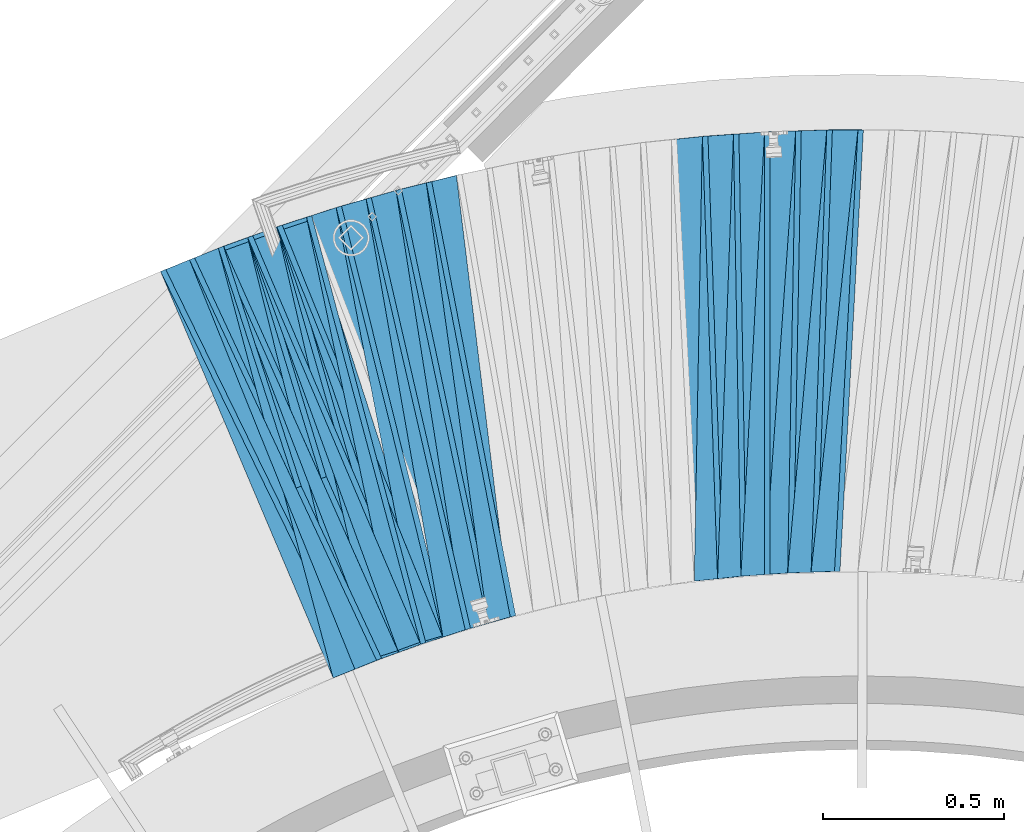
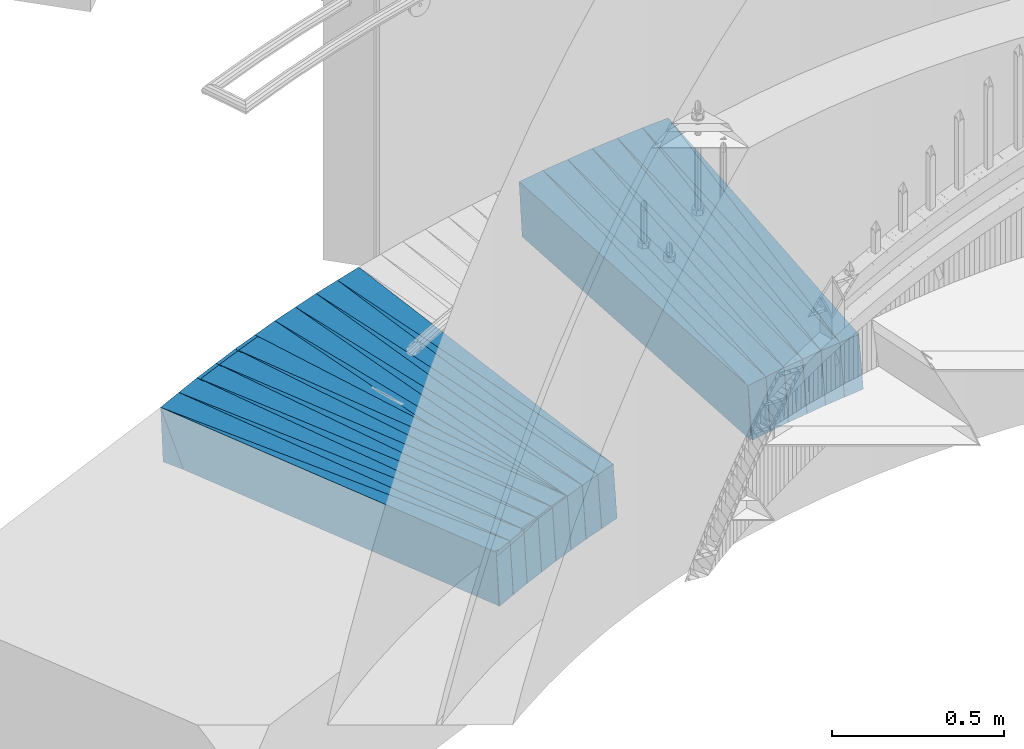
# One storey, part 837 of 975: 38 plates.
"""IFC2X3 building model written with IfcOpenShell, lengths in millimetres."""

from ifc_helpers import new_model, si_unit, frame, origin_with_axes, place, context, subcontext, project, spatial, faceted_brep, material, type_object, element, save


model = new_model("IFC2X3")

# Units and contexts
model_context = context("Model", 3, precision=1e-05, world=origin_with_axes())
body_context = subcontext(model_context, "Body", "Model", "MODEL_VIEW")
ifc_project = project(units=[si_unit("LENGTHUNIT", "METRE", prefix="MILLI"), si_unit("AREAUNIT", "SQUARE_METRE"), si_unit("VOLUMEUNIT", "CUBIC_METRE"), si_unit("MASSUNIT", "GRAM", prefix="KILO"), si_unit("TIMEUNIT", "SECOND"), si_unit("PLANEANGLEUNIT", "RADIAN"), si_unit("SOLIDANGLEUNIT", "STERADIAN"), si_unit("THERMODYNAMICTEMPERATUREUNIT", "DEGREE_CELSIUS"), si_unit("LUMINOUSINTENSITYUNIT", "LUMEN")], contexts=[model_context])

# Site, building, storey
site_placement = place(None, origin_with_axes())
site = spatial("IfcSite", under=ifc_project, at=site_placement, CompositionType="ELEMENT")
building_placement = place(site_placement, origin_with_axes())
building = spatial("IfcBuilding", under=site, at=building_placement, Name="Undefined", CompositionType="ELEMENT")
storey_placement = place(building_placement, origin_with_axes())
storey = spatial("IfcBuildingStorey", under=building, at=storey_placement, Name="Undefined", CompositionType="ELEMENT", Elevation=0.0)

# Plates
ifc_material = material(Name="STEEL/A36")
plate_type_1 = type_object("IfcPlateType", PredefinedType="NOTDEFINED")
plate_1_placement = place(storey_placement, frame((33135.7544163634, 8064.57326011908, -80.0313597914393), z_axis=(0.925334945859308, 0.374702572895314, 0.0579069929903383), x_axis=(0.375109260845974, -0.926971575619367, 0.00409150599831995)))
element("IfcPlate", 1, at=plate_1_placement, inside=storey, type_object=plate_type_1, material=ifc_material, Name="SLAB", context=body_context, shape_type="Brep", body=[
    faceted_brep([(-6.82121026329696e-12, -100.000000000011, -1.09139364212751e-10), (6.13964843744816, -100.000000000007, 85.9115524290755), (6.13964843754457, 100.000000000007, 85.9115524293229), (5.91171556152403e-12, 100.000000000011, 1.09139364212751e-10), (1222.04394531102, -100.000000000158, -3.23780113831162e-09), (1222.04394531112, 99.9999999998563, -2.99041857942939e-09)], [[[0, 1, 2, 3]], [[1, 4, 5, 2]], [[4, 0, 3, 5]], [[5, 3, 2]], [[4, 1, 0]]]),
])
plate_2_placement = place(storey_placement, frame((33054.8117538356, 8035.13147844104, -84.9380845994768), z_axis=(0.918671409330984, 0.390926168424825, 0.05674127702571), x_axis=(0.391343912095998, -0.920235746225737, 0.0040142040009847)))
element("IfcPlate", 2, at=plate_2_placement, inside=storey, type_object=plate_type_1, material=ifc_material, Name="SLAB", context=body_context, shape_type="Brep", body=[
    faceted_brep([(-6.82121026329696e-12, -100.000000000011, -1.09139364212751e-10), (4.49330329882287, -100.000000000016, 86.0390014645745), (4.49330329902114, 100.000000000009, 86.0390014649965), (5.91171556152403e-12, 100.000000000011, 1.09139364212751e-10), (1220.66552734293, -100.000000000056, -2.88127921521664e-09), (1220.66552734313, 99.9999999999702, -2.459273673594e-09)], [[[0, 1, 2, 3]], [[1, 4, 5, 2]], [[4, 0, 3, 5]], [[5, 3, 2]], [[4, 1, 0]]]),
])
plate_3_placement = place(storey_placement, frame((32974.0885574028, 8005.86513753065, -89.9313487506862), z_axis=(0.911678885621115, 0.406802370995397, 0.0579088979792043), x_axis=(0.407266029137052, -0.913300411307338, 0.00409148100137684)))
element("IfcPlate", 3, at=plate_3_placement, inside=storey, type_object=plate_type_1, material=ifc_material, Name="SLAB", context=body_context, shape_type="Brep", body=[
    faceted_brep([(-6.82121026329696e-12, -100.000000000011, -1.09139364212751e-10), (6.07652044296265, -99.9999999999998, 85.9131851196362), (6.07652044284623, 99.9999999999782, 85.9131851192578), (5.91171556152403e-12, 100.000000000011, 1.09139364212751e-10), (1222.05139160054, -100.000000000137, -7.20319803804159e-10), (1222.05139160042, 99.9999999998413, -1.0986695997417e-09)], [[[0, 1, 2, 3]], [[1, 4, 5, 2]], [[4, 0, 3, 5]], [[5, 3, 2]], [[4, 1, 0]]]),
])
plate_4_placement = place(storey_placement, frame((32894.2472778231, 7973.71949863962, -94.8378728433739), z_axis=(0.904478489317947, 0.422723148554099, 0.0567785350078129), x_axis=(0.42319595791562, -0.906029286819346, 0.00401405399919963)))
element("IfcPlate", 4, at=plate_4_placement, inside=storey, type_object=plate_type_1, material=ifc_material, Name="SLAB", context=body_context, shape_type="Brep", body=[
    faceted_brep([(-6.82121026329696e-12, -100.000000000011, -1.09139364212751e-10), (4.57424354575505, -99.9999999999789, 85.9768371585524), (4.57424354547129, 99.9999999999941, 85.9768371580867), (5.91171556152403e-12, 100.000000000011, 1.09139364212751e-10), (1220.71105957185, -99.999999999741, 6.00994098931551e-09), (1220.71105957157, 100.000000000232, 5.54427970200777e-09)], [[[0, 1, 2, 3]], [[1, 4, 5, 2]], [[4, 0, 3, 5]], [[5, 3, 2]], [[4, 1, 0]]]),
])
plate_5_placement = place(storey_placement, frame((32814.5117097274, 7941.65240086744, -99.8316186181916), z_axis=(0.896919890625574, 0.438390985101554, 0.0578623710359128), x_axis=(0.438909982988445, -0.898521723976347, 0.0040912559998923)))
element("IfcPlate", 5, at=plate_5_placement, inside=storey, type_object=plate_type_1, material=ifc_material, Name="SLAB", context=body_context, shape_type="Brep", body=[
    faceted_brep([(-6.82121026329696e-12, -100.000000000011, -1.09139364212751e-10), (6.11307334909816, -99.9999999999957, 85.9797058106051), (6.11307334904541, 100.000000000008, 85.9797058106778), (5.91171556152403e-12, 100.000000000011, 1.09139364212751e-10), (1222.11853027179, -100.000000000163, -1.24418875202537e-09), (1222.11853027174, 99.9999999998415, -1.17870513349771e-09)], [[[0, 1, 2, 3]], [[1, 4, 5, 2]], [[4, 0, 3, 5]], [[5, 3, 2]], [[4, 1, 0]]]),
])
plate_6_placement = place(storey_placement, frame((34654.3102342191, 8330.60518954007, 9.29064641898812), z_axis=(0.99768231764346, -0.0356859870933057, 0.0579353379790892), x_axis=(-0.0355132029959172, -0.999361163885047, -0.0040095549995388)))
element("IfcPlate", 6, at=plate_6_placement, inside=storey, type_object=plate_type_1, material=ifc_material, Name="SLAB", context=body_context, shape_type="Brep", body=[
    faceted_brep([(-6.82121026329696e-12, -100.000000000011, -1.09139364212751e-10), (-3.07418322551348, -100.000000000018, 86.0903549191207), (-3.07418322569538, 99.9999999999866, 86.0903549192008), (5.91171556152403e-12, 100.000000000011, 1.09139364212751e-10), (1222.0806884773, -99.9999999999006, 8.14907252788544e-10), (1222.08068847711, 100.000000000104, 8.94942786544561e-10)], [[[0, 1, 2, 3]], [[1, 4, 5, 2]], [[4, 0, 3, 5]], [[5, 3, 2]], [[4, 1, 0]]]),
])
plate_7_placement = place(storey_placement, frame((34568.2904770862, 8327.71651932735, 4.38403457644043), z_axis=(0.998217432917803, -0.0183894461560285, 0.0567783839948426), x_axis=(-0.0181861060034705, -0.999826229190945, -0.00409597000078224)))
element("IfcPlate", 7, at=plate_7_placement, inside=storey, type_object=plate_type_1, material=ifc_material, Name="SLAB", context=body_context, shape_type="Brep", body=[
    faceted_brep([(-6.82121026329696e-12, -100.000000000011, -1.09139364212751e-10), (-4.58173561107287, -99.9999999999939, 85.9699249268597), (-4.5817356109892, 100.000000000015, 85.9699249270125), (5.91171556152403e-12, 100.000000000011, 1.09139364212751e-10), (1220.71215820214, -100.000000000078, -8.87666828930378e-10), (1220.71215820222, 99.9999999999311, -7.27595761418343e-10)], [[[0, 1, 2, 3]], [[1, 4, 5, 2]], [[4, 0, 3, 5]], [[5, 3, 2]], [[4, 1, 0]]]),
])
plate_8_placement = place(storey_placement, frame((34482.3961116413, 8324.81606906158, -0.609540547740721), z_axis=(0.998322212679924, -0.000808766746195034, 0.0578973709784079), x_axis=(-0.000572827000131128, -0.99999146522926, -0.00409161800093805)))
element("IfcPlate", 8, at=plate_8_placement, inside=storey, type_object=plate_type_1, material=ifc_material, Name="SLAB", context=body_context, shape_type="Brep", body=[
    faceted_brep([(-6.82121026329696e-12, -100.000000000011, -1.09139364212751e-10), (-3.06969547265362, -99.9999999999859, 86.1427688601034), (-3.06969547271365, 100.000000000016, 86.1427688601398), (5.91171556152403e-12, 100.000000000011, 1.09139364212751e-10), (1222.01037597622, -99.9999999997835, 2.84489942714572e-09), (1222.01037597616, 100.000000000219, 2.87400325760245e-09)], [[[0, 1, 2, 3]], [[1, 4, 5, 2]], [[4, 0, 3, 5]], [[5, 3, 2]], [[4, 1, 0]]]),
])
plate_9_placement = place(storey_placement, frame((34396.5889540769, 8318.90883943182, -5.60953580880143), z_axis=(0.998185261867998, 0.0165334455942793, 0.0579036109953177), x_axis=(0.0167938909966302, -0.99985091479929, -0.0040141499991942)))
element("IfcPlate", 9, at=plate_9_placement, inside=storey, type_object=plate_type_1, material=ifc_material, Name="SLAB", context=body_context, shape_type="Brep", body=[
    faceted_brep([(-6.82121026329696e-12, -100.000000000011, -1.09139364212751e-10), (-4.57826042168381, -99.9999999999934, 86.0330123902531), (-4.57826042180659, 99.9999999999723, 86.0330123896492), (5.91171556152403e-12, 100.000000000011, 1.09139364212751e-10), (1220.68200683563, -100.000000000135, -3.16504156216979e-09), (1220.68200683551, 99.9999999998304, -3.76894604414701e-09)], [[[0, 1, 2, 3]], [[1, 4, 5, 2]], [[4, 0, 3, 5]], [[5, 3, 2]], [[4, 1, 0]]]),
])
plate_10_placement = place(storey_placement, frame((34310.6662014911, 8313.00565710343, -10.5160408832295), z_axis=(0.997807948087931, 0.0340047279225218, 0.0567712710045234), x_axis=(0.0342872570145879, -0.999403975425247, -0.00400972700170614)))
element("IfcPlate", 10, at=plate_10_placement, inside=storey, type_object=plate_type_1, material=ifc_material, Name="SLAB", context=body_context, shape_type="Brep", body=[
    faceted_brep([(-6.82121026329696e-12, -100.000000000011, -1.09139364212751e-10), (-3.07422494894672, -100.000000000028, 86.0941314692318), (-3.07422494880666, 100.00000000001, 86.0941314699012), (5.91171556152403e-12, 100.000000000011, 1.09139364212751e-10), (1222.028320313, -99.9999999997735, 3.09228198602796e-09), (1222.02832031314, 100.000000000264, 3.74711817130446e-09)], [[[0, 1, 2, 3]], [[1, 4, 5, 2]], [[4, 0, 3, 5]], [[5, 3, 2]], [[4, 1, 0]]]),
])
plate_11_placement = place(storey_placement, frame((34225.1547439435, 8304.21269766823, -15.4159947531042), z_axis=(0.997064626260986, 0.0513704985322983, 0.0567732590185078), x_axis=(0.0516856390081038, -0.998655006156567, -0.00409553400064209)))
element("IfcPlate", 11, at=plate_11_placement, inside=storey, type_object=plate_type_1, material=ifc_material, Name="SLAB", context=body_context, shape_type="Brep", body=[
    faceted_brep([(-6.82121026329696e-12, -100.000000000011, -1.09139364212751e-10), (-4.48897552489962, -100.000000000009, 85.9844131468126), (-4.4889755247832, 99.9999999999895, 85.984413146798), (5.91171556152403e-12, 100.000000000011, 1.09139364212751e-10), (1220.84204101581, -99.9999999999025, 1.3606040738523e-09), (1220.84204101593, 100.000000000096, 1.34605215862393e-09)], [[[0, 1, 2, 3]], [[1, 4, 5, 2]], [[4, 0, 3, 5]], [[5, 3, 2]], [[4, 1, 0]]]),
])
plate_12_placement = place(storey_placement, frame((33548.10251818, 8185.5918526889, -55.1159741349392), z_axis=(0.980220135834761, 0.189591330106346, 0.0567768689924804), x_axis=(0.190124738905457, -0.98175139851181, -0.00409575099796333)))
element("IfcPlate", 12, at=plate_12_placement, inside=storey, type_object=plate_type_1, material=ifc_material, Name="SLAB", context=body_context, shape_type="Brep", body=[
    faceted_brep([(-6.82121026329696e-12, -100.000000000011, -1.09139364212751e-10), (-4.58409500121365, -100.000000000006, 85.972068786512), (-4.58409500123116, 99.9999999999845, 85.9720687863446), (5.91171556152403e-12, 100.000000000011, 1.09139364212751e-10), (1220.77746581972, -100.000000000143, -2.42289388552308e-09), (1220.7774658197, 99.9999999998472, -2.58296495303512e-09)], [[[0, 1, 2, 3]], [[1, 4, 5, 2]], [[4, 0, 3, 5]], [[5, 3, 2]], [[4, 1, 0]]]),
])
plate_13_placement = place(storey_placement, frame((33464.6854573092, 8164.91091690286, -60.1095362531746), z_axis=(0.976677374854116, 0.206758578517145, 0.0578981490001352), x_axis=(0.207336381074921, -0.978261155353486, -0.00409108900147828)))
element("IfcPlate", 13, at=plate_13_placement, inside=storey, type_object=plate_type_1, material=ifc_material, Name="SLAB", context=body_context, shape_type="Brep", body=[
    faceted_brep([(-6.82121026329696e-12, -100.000000000011, -1.09139364212751e-10), (-3.05569958679985, -99.9999999999884, 86.14263153098), (-3.0556995868626, 100.000000000006, 86.1426315308781), (5.91171556152403e-12, 100.000000000011, 1.09139364212751e-10), (1222.1685791026, -99.999999999809, 4.80940798297524e-09), (1222.16857910253, 100.000000000186, 4.70026861876249e-09)], [[[0, 1, 2, 3]], [[1, 4, 5, 2]], [[4, 0, 3, 5]], [[5, 3, 2]], [[4, 1, 0]]]),
])
plate_14_placement = place(storey_placement, frame((33382.0618861938, 8141.30909607644, -65.1092290061584), z_axis=(0.972940396062581, 0.223670947357811, 0.057950780992559), x_axis=(0.224277288055524, -0.974516764241257, -0.00409564100101394)))
element("IfcPlate", 14, at=plate_14_placement, inside=storey, type_object=plate_type_1, material=ifc_material, Name="SLAB", context=body_context, shape_type="Brep", body=[
    faceted_brep([(-6.82121026329696e-12, -100.000000000011, -1.09139364212751e-10), (-4.59122133275122, -100.000000000034, 85.9556350701896), (-4.59122133255295, 100.000000000001, 85.9556350708372), (5.91171556152403e-12, 100.000000000011, 1.09139364212751e-10), (1220.81018066428, -99.9999999999636, 6.11180439591408e-10), (1220.81018066448, 100.000000000072, 1.25874066725373e-09)], [[[0, 1, 2, 3]], [[1, 4, 5, 2]], [[4, 0, 3, 5]], [[5, 3, 2]], [[4, 1, 0]]]),
])
plate_15_placement = place(storey_placement, frame((33299.3298961109, 8117.69733138061, -70.1094642624618), z_axis=(0.968857704020745, 0.240749774635547, 0.0579162789946261), x_axis=(0.241378352921973, -0.970422802686305, -0.00400933499870396)))
element("IfcPlate", 15, at=plate_15_placement, inside=storey, type_object=plate_type_1, material=ifc_material, Name="SLAB", context=body_context, shape_type="Brep", body=[
    faceted_brep([(-6.82121026329696e-12, -100.000000000011, -1.09139364212751e-10), (-3.05707740787153, -100.000000000005, 86.1198806761822), (-3.05707740773124, 100.000000000014, 86.1198806765024), (5.91171556152403e-12, 100.000000000011, 1.09139364212751e-10), (1222.14770507768, -100.000000000215, -3.7762220017612e-09), (1222.14770507782, 99.9999999998026, -3.45607986673713e-09)], [[[0, 1, 2, 3]], [[1, 4, 5, 2]], [[4, 0, 3, 5]], [[5, 3, 2]], [[4, 1, 0]]]),
])
plate_16_placement = place(storey_placement, frame((33217.3817456484, 8091.17099343573, -75.0162061581968), z_axis=(0.964591757229109, 0.257572832400976, 0.0567360370011757), x_axis=(0.258211110919565, -0.966079833699058, -0.00409598799872406)))
element("IfcPlate", 16, at=plate_16_placement, inside=storey, type_object=plate_type_1, material=ifc_material, Name="SLAB", context=body_context, shape_type="Brep", body=[
    faceted_brep([(-6.82121026329696e-12, -100.000000000011, -1.09139364212751e-10), (-4.59612512584135, -100.000000000003, 86.0330505371167), (-4.59612512593594, 99.9999999999959, 86.0330505370575), (5.91171556152403e-12, 100.000000000011, 1.09139364212751e-10), (1220.70654296677, -100.000000000073, 1.41517375595868e-09), (1220.70654296638, 99.9999999999, 1.13868736661971e-09)], [[[0, 1, 2, 3]], [[1, 4, 5, 2]], [[4, 0, 3, 5]], [[5, 3, 2]], [[4, 1, 0]]]),
])
plate_17_placement = place(storey_placement, frame((33135.6649064035, 8064.68931384774, -80.0094190697999), z_axis=(0.959862355266752, 0.274424968776591, 0.057924049010159), x_axis=(0.275107969080175, -0.961404976280192, -0.00400960500116856)))
element("IfcPlate", 17, at=plate_17_placement, inside=storey, type_object=plate_type_1, material=ifc_material, Name="SLAB", context=body_context, shape_type="Brep", body=[
    faceted_brep([(-6.82121026329696e-12, -100.000000000011, -1.09139364212751e-10), (-3.08999657691311, -99.999999999991, 86.1060485840826), (-3.08999657622189, 99.9999999999988, 86.1060485839635), (5.91171556152403e-12, 100.000000000011, 1.09139364212751e-10), (1222.06604003649, -99.9999999999675, -8.78571881912649e-10), (1222.0660400372, 100.000000000023, -9.97715687844902e-10)], [[[0, 1, 2, 3]], [[1, 4, 5, 2]], [[4, 0, 3, 5]], [[5, 3, 2]], [[4, 1, 0]]]),
])
plate_18_placement = place(storey_placement, frame((33054.7158265501, 8035.35783202238, -84.9160779092227), z_axis=(0.955029910052192, 0.29102634265426, 0.0567586009956872), x_axis=(0.291716547101264, -0.956496042332032, -0.00409599200142186)))
element("IfcPlate", 18, at=plate_18_placement, inside=storey, type_object=plate_type_1, material=ifc_material, Name="SLAB", context=body_context, shape_type="Brep", body=[
    faceted_brep([(-6.82121026329696e-12, -100.000000000011, -1.09139364212751e-10), (-4.57035684590414, -100.000000000011, 86.000709533495), (-4.57035684574521, 100.000000000007, 86.0007095338296), (5.91171556152403e-12, 100.000000000011, 1.09139364212751e-10), (1220.70556640622, -100.00000000004, -9.89530235528946e-10), (1220.70556640638, 99.9999999999779, -6.47560227662325e-10)], [[[0, 1, 2, 3]], [[1, 4, 5, 2]], [[4, 0, 3, 5]], [[5, 3, 2]], [[4, 1, 0]]]),
])
plate_19_placement = place(storey_placement, frame((32973.9921392187, 8006.08652875833, -89.9092683894986), z_axis=(0.949728127827527, 0.307666932996518, 0.0579442969906189), x_axis=(0.30840806390351, -0.951245355702387, -0.00409137799871994)))
element("IfcPlate", 19, at=plate_19_placement, inside=storey, type_object=plate_type_1, material=ifc_material, Name="SLAB", context=body_context, shape_type="Brep", body=[
    faceted_brep([(-6.82121026329696e-12, -100.000000000011, -1.09139364212751e-10), (-3.06769871705592, -99.9999999999841, 86.0731582644294), (-3.06769871702454, 100.000000000017, 86.0731582644512), (5.91171556152403e-12, 100.000000000011, 1.09139364212751e-10), (1222.0821533214, -100.000000000009, 3.27781890518963e-09), (1222.08215332196, 100.000000000009, 3.46881279256195e-09)], [[[0, 1, 2, 3]], [[1, 4, 5, 2]], [[4, 0, 3, 5]], [[5, 3, 2]], [[4, 1, 0]]]),
])
plate_type_2 = type_object("IfcPlateType", PredefinedType="NOTDEFINED")
plate_20_placement = place(storey_placement, frame((33137.5229862125, 8065.28950076047, -79.9023638409879), z_axis=(0.942714658867744, 0.324569264568046, 0.0770964620046297), x_axis=(0.325538183915046, -0.945528894753245, 0.0)))
element("IfcPlate", 20, at=plate_20_placement, inside=storey, type_object=plate_type_2, material=ifc_material, Name="SLAB", context=body_context, shape_type="Brep", body=[
    faceted_brep([(-6.82121026329696e-12, -100.000000000011, -1.09139364212751e-10), (1220.32177734203, -100.000000000288, 64.8538207970487), (1220.32177734188, 99.9999999996785, 64.8538207966412), (5.91171556152403e-12, 100.000000000011, 1.09139364212751e-10), (1219.21179199108, -100.000000000276, -3.688910510391e-09), (1219.21179199089, 99.9999999996767, -4.27098711952567e-09)], [[[0, 1, 2, 3]], [[1, 4, 5, 2]], [[4, 0, 3, 5]], [[5, 3, 2]], [[4, 1, 0]]]),
])
plate_21_placement = place(storey_placement, frame((33056.5268579072, 8035.86139024093, -84.81467443299), z_axis=(0.937018772940687, 0.341024117840773, 0.0754875500175482), x_axis=(0.341999931072196, -0.939699977198368, 0.0)))
element("IfcPlate", 21, at=plate_21_placement, inside=storey, type_object=plate_type_2, material=ifc_material, Name="SLAB", context=body_context, shape_type="Brep", body=[
    faceted_brep([(-6.82121026329696e-12, -100.000000000011, -1.09139364212751e-10), (1218.93835449151, -100.000000000033, 64.9113693233012), (1218.9383544917, 100.000000000012, 64.9113693238905), (5.91171556152403e-12, 100.000000000011, 1.09139364212751e-10), (1219.00610351704, -99.9999999999638, 2.39924702327698e-09), (1219.00610351748, 100.000000000048, 2.53930920735002e-09)], [[[0, 1, 2, 3]], [[1, 4, 5, 2]], [[4, 0, 3, 5]], [[5, 3, 2]], [[4, 1, 0]]]),
])
plate_22_placement = place(storey_placement, frame((32975.8285918491, 8006.641644218, -89.8025547789074), z_axis=(0.930807378832721, 0.357291990395312, 0.0770717659711769), x_axis=(0.35835790887939, -0.933584280685783, 0.0)))
element("IfcPlate", 22, at=plate_22_placement, inside=storey, type_object=plate_type_2, material=ifc_material, Name="SLAB", context=body_context, shape_type="Brep", body=[
    faceted_brep([(-6.82121026329696e-12, -100.000000000011, -1.09139364212751e-10), (1220.3281250008, -99.9999999998554, 64.8746032733543), (1220.32812500072, 100.000000000123, 64.8746032730778), (5.91171556152403e-12, 100.000000000011, 1.09139364212751e-10), (1219.17224121067, -100.000000000208, -4.02360456064343e-09), (1219.17224121068, 99.9999999998308, -3.41242412105203e-09)], [[[0, 1, 2, 3]], [[1, 4, 5, 2]], [[4, 0, 3, 5]], [[5, 3, 2]], [[4, 1, 0]]]),
])
plate_23_placement = place(storey_placement, frame((32895.9316893399, 7974.50681358159, -94.7147429945766), z_axis=(0.924559123474132, 0.373488184940868, 0.0754784930316003), x_axis=(0.374556633970614, -0.927204037927253, 0.0)))
element("IfcPlate", 23, at=plate_23_placement, inside=storey, type_object=plate_type_2, material=ifc_material, Name="SLAB", context=body_context, shape_type="Brep", body=[
    faceted_brep([(-6.82121026329696e-12, -100.000000000011, -1.09139364212751e-10), (1218.9836425786, -99.9999999999404, 64.9191513069381), (1218.98364257841, 100.000000000018, 64.9191513063852), (5.91171556152403e-12, 100.000000000011, 1.09139364212751e-10), (1219.04125976613, -99.9999999999304, -7.93079379945993e-10), (1219.04125976594, 100.000000000028, -1.33877620100975e-09)], [[[0, 1, 2, 3]], [[1, 4, 5, 2]], [[4, 0, 3, 5]], [[5, 3, 2]], [[4, 1, 0]]]),
])
plate_24_placement = place(storey_placement, frame((32816.2272861468, 7942.49101329973, -99.7025945126019), z_axis=(0.917763717501001, 0.389577327556958, 0.0770666250222656), x_axis=(0.390739407987306, -0.920501338970091, 0.0)))
element("IfcPlate", 24, at=plate_24_placement, inside=storey, type_object=plate_type_2, material=ifc_material, Name="SLAB", context=body_context, shape_type="Brep", body=[
    faceted_brep([(-6.82121026329696e-12, -100.000000000011, -1.09139364212751e-10), (1220.39514160142, -100.000000000033, 64.8789291377689), (1220.39514160142, 99.9999999999832, 64.8789291379508), (5.91171556152403e-12, 100.000000000011, 1.09139364212751e-10), (1219.22692871079, -100.000000000036, -1.78260961547494e-09), (1219.22692871079, 99.9999999999791, -1.59343471750617e-09)], [[[0, 1, 2, 3]], [[1, 4, 5, 2]], [[4, 0, 3, 5]], [[5, 3, 2]], [[4, 1, 0]]]),
])
plate_25_placement = place(storey_placement, frame((34656.2068172403, 8330.53727817186, 9.41890173874354), z_axis=(0.993138754630153, -0.0883666426716279, 0.0765947159705827), x_axis=(-0.0880073789863377, -0.996087214845347, -0.00805987999874862)))
element("IfcPlate", 25, at=plate_25_placement, inside=storey, type_object=plate_type_2, material=ifc_material, Name="SLAB", context=body_context, shape_type="Brep", body=[
    faceted_brep([(-6.82121026329696e-12, -100.000000000011, -1.09139364212751e-10), (1220.38037109444, -100.000000000198, 64.4446411107783), (1220.38037109458, 99.9999999997917, 64.4446411106474), (5.91171556152403e-12, 100.000000000011, 1.09139364212751e-10), (1228.30615234451, -100.000000000205, -2.4156179279089e-09), (1228.30615234465, 99.9999999997844, -2.53930920735002e-09)], [[[0, 1, 2, 3]], [[1, 4, 5, 2]], [[4, 0, 3, 5]], [[5, 3, 2]], [[4, 1, 0]]]),
])
plate_26_placement = place(storey_placement, frame((34484.1414844147, 8324.81459238544, -0.492993083092188), z_axis=(0.995738613782783, -0.0536196746265631, 0.0750302839850965), x_axis=(-0.0531639039878298, -0.998553270771408, -0.00806007099815486)))
element("IfcPlate", 26, at=plate_26_placement, inside=storey, type_object=plate_type_2, material=ifc_material, Name="SLAB", context=body_context, shape_type="Brep", body=[
    faceted_brep([(-6.82121026329696e-12, -100.000000000011, -1.09139364212751e-10), (1220.3095703117, -100.000000000303, 64.4510726887602), (1220.30957031172, 99.9999999997431, 64.4510726893786), (5.91171556152403e-12, 100.000000000011, 1.09139364212751e-10), (1228.27697753823, -100.000000000306, -4.79485606774688e-09), (1228.27697753825, 99.9999999997403, -4.1691237129271e-09)], [[[0, 1, 2, 3]], [[1, 4, 5, 2]], [[4, 0, 3, 5]], [[5, 3, 2]], [[4, 1, 0]]]),
])
plate_27_placement = place(storey_placement, frame((34398.3374454873, 8318.93773881275, -5.49272363638653), z_axis=(0.996519004754703, -0.0362445332202716, 0.0750746759855925), x_axis=(-0.0357455760147824, -0.999329064413317, -0.00797965000330034)))
element("IfcPlate", 27, at=plate_27_placement, inside=storey, type_object=plate_type_2, material=ifc_material, Name="SLAB", context=body_context, shape_type="Brep", body=[
    faceted_brep([(-6.82121026329696e-12, -100.000000000011, -1.09139364212751e-10), (1218.98742675687, -100.000000000176, 64.2972259496964), (1218.98742675695, 99.9999999997913, 64.2972259492672), (5.91171556152403e-12, 100.000000000011, 1.09139364212751e-10), (1228.12402343649, -100.000000000161, -1.58615875989199e-09), (1228.12402343657, 99.9999999998063, -2.02271621674299e-09)], [[[0, 1, 2, 3]], [[1, 4, 5, 2]], [[4, 0, 3, 5]], [[5, 3, 2]], [[4, 1, 0]]]),
])
plate_28_placement = place(storey_placement, frame((34312.6888105105, 8313.07450380581, -10.3803591534103), z_axis=(0.996877643470711, -0.0188008292251634, 0.0766908910414286), x_axis=(-0.0182359309970264, -0.999801226837093, -0.00805962999868677)))
element("IfcPlate", 28, at=plate_28_placement, inside=storey, type_object=plate_type_2, material=ifc_material, Name="SLAB", context=body_context, shape_type="Brep", body=[
    faceted_brep([(-6.82121026329696e-12, -100.000000000011, -1.09139364212751e-10), (1220.33264160152, -100.000000000136, 64.3548431378658), (1220.33264160136, 99.9999999998754, 64.3548431379968), (5.91171556152403e-12, 100.000000000011, 1.09139364212751e-10), (1228.34411621094, -100.000000000128, -1.45519152283669e-09), (1228.34411621078, 99.9999999998836, -1.32422428578138e-09)], [[[0, 1, 2, 3]], [[1, 4, 5, 2]], [[4, 0, 3, 5]], [[5, 3, 2]], [[4, 1, 0]]]),
])
plate_29_placement = place(storey_placement, frame((33466.5499595054, 8165.3055479217, -59.9807341548271), z_axis=(0.985003841547662, 0.154579198307659, 0.0766335669723834), x_axis=(0.155648055952591, -0.98777903069915, -0.00814058899752061)))
element("IfcPlate", 29, at=plate_29_placement, inside=storey, type_object=plate_type_2, material=ifc_material, Name="SLAB", context=body_context, shape_type="Brep", body=[
    faceted_brep([(-6.82121026329696e-12, -100.000000000011, -1.09139364212751e-10), (1220.47058105458, -100.00000000003, 64.4019165035206), (1220.47058105446, 99.9999999999168, 64.4019165028149), (5.91171556152403e-12, 100.000000000011, 1.09139364212751e-10), (1228.41235351556, -100.000000000024, -1.1859810911119e-09), (1228.41235351543, 99.9999999999231, -1.88447302207351e-09)], [[[0, 1, 2, 3]], [[1, 4, 5, 2]], [[4, 0, 3, 5]], [[5, 3, 2]], [[4, 1, 0]]]),
])
plate_30_placement = place(storey_placement, frame((33301.1737668346, 8118.15543659717, -69.9810812451679), z_axis=(0.97901264480495, 0.188857485795306, 0.0765969410034906), x_axis=(0.19001573493331, -0.981747961655433, -0.00805979299717123)))
element("IfcPlate", 30, at=plate_30_placement, inside=storey, type_object=plate_type_2, material=ifc_material, Name="SLAB", context=body_context, shape_type="Brep", body=[
    faceted_brep([(-6.82121026329696e-12, -100.000000000011, -1.09139364212751e-10), (1220.4472656248, -100.000000000305, 64.4484252889524), (1220.44726562479, 99.9999999997121, 64.4484252891634), (5.91171556152403e-12, 100.000000000011, 1.09139364212751e-10), (1228.31933593596, -99.9999999999067, -4.36557456851006e-11), (1228.31933593586, 100.000000000093, -9.77706804405898e-11)], [[[0, 1, 2, 3]], [[1, 4, 5, 2]], [[4, 0, 3, 5]], [[5, 3, 2]], [[4, 1, 0]]]),
])
plate_31_placement = place(storey_placement, frame((33137.4851565377, 8065.20964877154, -79.8815428958601), z_axis=(0.971836439509257, 0.22288125128347, 0.0765368059712765), x_axis=(0.224132680059666, -0.974525309259414, -0.00805998400214553)))
element("IfcPlate", 31, at=plate_31_placement, inside=storey, type_object=plate_type_2, material=ifc_material, Name="SLAB", context=body_context, shape_type="Brep", body=[
    faceted_brep([(-6.82121026329696e-12, -100.000000000011, -1.09139364212751e-10), (1220.3635253946, -100.000000000103, 64.4856185901835), (1220.36352539395, 99.9999999999128, 64.4856185902686), (5.91171556152403e-12, 100.000000000011, 1.09139364212751e-10), (1228.29028320695, -100.000000000096, -4.76802597404458e-09), (1228.2902832063, 99.999999999919, -4.68162397737615e-09)], [[[0, 1, 2, 3]], [[1, 4, 5, 2]], [[4, 0, 3, 5]], [[5, 3, 2]], [[4, 1, 0]]]),
])
plate_32_placement = place(storey_placement, frame((32975.6547234667, 8006.62506123231, -89.792467966709), z_axis=(0.963571948094516, 0.2566886828057, 0.0751000730013924), x_axis=(0.257993762909297, -0.966112963660342, -0.00805976099716642)))
element("IfcPlate", 32, at=plate_32_placement, inside=storey, type_object=plate_type_2, material=ifc_material, Name="SLAB", context=body_context, shape_type="Brep", body=[
    faceted_brep([(-6.82121026329696e-12, -100.000000000011, -1.09139364212751e-10), (1220.38452148575, -99.9999999997212, 64.3941726722405), (1220.38452148574, 100.000000000259, 64.3941726719786), (5.91171556152403e-12, 100.000000000011, 1.09139364212751e-10), (1228.32421874839, -99.9999999999676, 2.85581336356699e-09), (1228.32421874773, 100.000000000042, 2.94858182314783e-09)], [[[0, 1, 2, 3]], [[1, 4, 5, 2]], [[4, 0, 3, 5]], [[5, 3, 2]], [[4, 1, 0]]]),
])
plate_type_3 = type_object("IfcPlateType", PredefinedType="NOTDEFINED")
plate_33_placement = place(storey_placement, frame((34742.0575927924, 8330.41910573923, 14.4074087300959), z_axis=(0.991562837620675, -0.105667369447647, 0.0750835939713189), x_axis=(-0.105359499970156, -0.994401528718322, -0.00806073499771668)))
element("IfcPlate", 33, at=plate_33_placement, inside=storey, type_object=plate_type_3, material=ifc_material, Name="SLAB", context=body_context, shape_type="Brep", body=[
    faceted_brep([(-6.82121026329696e-12, -100.000000000011, -1.09139364212751e-10), (1219.03247070296, -99.9999999998586, 64.2789917010814), (1219.03247070281, 100.000000000147, 64.2789917011469), (5.91171556152403e-12, 100.000000000011, 1.09139364212751e-10), (1228.17590332014, -99.9999999998468, 2.36468622460961e-09), (1228.17590331999, 100.00000000016, 2.43016984313726e-09)], [[[0, 1, 2, 3]], [[1, 4, 5, 2]], [[4, 0, 3, 5]], [[5, 3, 2]], [[4, 1, 0]]]),
])
plate_34_placement = place(storey_placement, frame((34570.3162155902, 8327.67911599647, 4.51990874449594), z_axis=(0.994520751554824, -0.0710139748360888, 0.0767169479633248), x_axis=(-0.0705965699901529, -0.997471714860862, -0.00814262599886418)))
element("IfcPlate", 34, at=plate_34_placement, inside=storey, type_object=plate_type_3, material=ifc_material, Name="SLAB", context=body_context, shape_type="Brep", body=[
    faceted_brep([(-6.82121026329696e-12, -100.000000000011, -1.09139364212751e-10), (1219.02221679768, -99.9999999999122, 64.2106094372502), (1219.02221679757, 100.000000000135, 64.2106094378614), (5.91171556152403e-12, 100.000000000011, 1.09139364212751e-10), (1228.10498046961, -99.9999999999159, 1.89902493730187e-09), (1228.10498046951, 100.000000000131, 2.49565346166492e-09)], [[[0, 1, 2, 3]], [[1, 4, 5, 2]], [[4, 0, 3, 5]], [[5, 3, 2]], [[4, 1, 0]]]),
])
plate_35_placement = place(storey_placement, frame((33550.0842962168, 8185.97507693501, -54.9806894578514), z_axis=(0.987559254130853, 0.137306745397209, 0.0766392670172415), x_axis=(0.138327030004346, -0.990353142031131, -0.00814167300025593)))
element("IfcPlate", 35, at=plate_35_placement, inside=storey, type_object=plate_type_3, material=ifc_material, Name="SLAB", context=body_context, shape_type="Brep", body=[
    faceted_brep([(-6.82121026329696e-12, -100.000000000011, -1.09139364212751e-10), (1219.08459472725, -99.9999999998181, 64.2671737695782), (1219.08459472724, 100.000000000191, 64.2671737696728), (5.91171556152403e-12, 100.000000000011, 1.09139364212751e-10), (1228.24877929757, -99.999999999804, 2.12457962334156e-09), (1228.24877929756, 100.000000000204, 2.22644302994013e-09)], [[[0, 1, 2, 3]], [[1, 4, 5, 2]], [[4, 0, 3, 5]], [[5, 3, 2]], [[4, 1, 0]]]),
])
plate_36_placement = place(storey_placement, frame((33383.770779914, 8141.70189160181, -64.9919762008636), z_axis=(0.982265277387351, 0.171770506409758, 0.0751652710158436), x_axis=(0.172850678945799, -0.984915058691145, -0.00806039399747238)))
element("IfcPlate", 36, at=plate_36_placement, inside=storey, type_object=plate_type_3, material=ifc_material, Name="SLAB", context=body_context, shape_type="Brep", body=[
    faceted_brep([(-6.82121026329696e-12, -100.000000000011, -1.09139364212751e-10), (1219.12023925791, -100.000000000155, 64.2130355815243), (1219.12023925793, 99.9999999998213, 64.2130355812187), (5.91171556152403e-12, 100.000000000011, 1.09139364212751e-10), (1228.2277832032, -100.000000000156, -2.74303602054715e-09), (1228.22778320322, 99.9999999998208, -3.04862624034286e-09)], [[[0, 1, 2, 3]], [[1, 4, 5, 2]], [[4, 0, 3, 5]], [[5, 3, 2]], [[4, 1, 0]]]),
])
plate_37_placement = place(storey_placement, frame((33219.1871093923, 8091.65300131885, -74.8924550297347), z_axis=(0.975673045502563, 0.205965640082511, 0.0751016869661145), x_axis=(0.207136208008271, -0.978278905039061, -0.00806072500032185)))
element("IfcPlate", 37, at=plate_37_placement, inside=storey, type_object=plate_type_3, material=ifc_material, Name="SLAB", context=body_context, shape_type="Brep", body=[
    faceted_brep([(-6.82121026329696e-12, -100.000000000011, -1.09139364212751e-10), (1219.01391601546, -99.999999999884, 64.2613601700214), (1219.01391601562, 100.000000000153, 64.2613601705525), (5.91171556152403e-12, 100.000000000011, 1.09139364212751e-10), (1228.17736816387, -99.9999999998922, 1.666194293648e-09), (1228.17736816402, 100.000000000145, 2.19006324186921e-09)], [[[0, 1, 2, 3]], [[1, 4, 5, 2]], [[4, 0, 3, 5]], [[5, 3, 2]], [[4, 1, 0]]]),
])
plate_38_placement = place(storey_placement, frame((33056.6473051179, 8035.94632382515, -84.7807801434468), z_axis=(0.967797434526491, 0.239783997183708, 0.076627412970466), x_axis=(0.241090461033521, -0.970468492134927, -0.00814219700113204)))
element("IfcPlate", 38, at=plate_38_placement, inside=storey, type_object=plate_type_3, material=ifc_material, Name="SLAB", context=body_context, shape_type="Brep", body=[
    faceted_brep([(-6.82121026329696e-12, -100.000000000011, -1.09139364212751e-10), (1219.01208496235, -99.9999999997126, 64.2777328529628), (1219.01208496237, 100.000000000286, 64.2777328529628), (5.91171556152403e-12, 100.000000000011, 1.09139364212751e-10), (1228.16967773582, -99.999999999703, 3.29600879922509e-09), (1228.16967773584, 100.000000000296, 3.29600879922509e-09)], [[[0, 1, 2, 3]], [[1, 4, 5, 2]], [[4, 0, 3, 5]], [[5, 3, 2]], [[4, 1, 0]]]),
])

save(model, "model.ifc")
